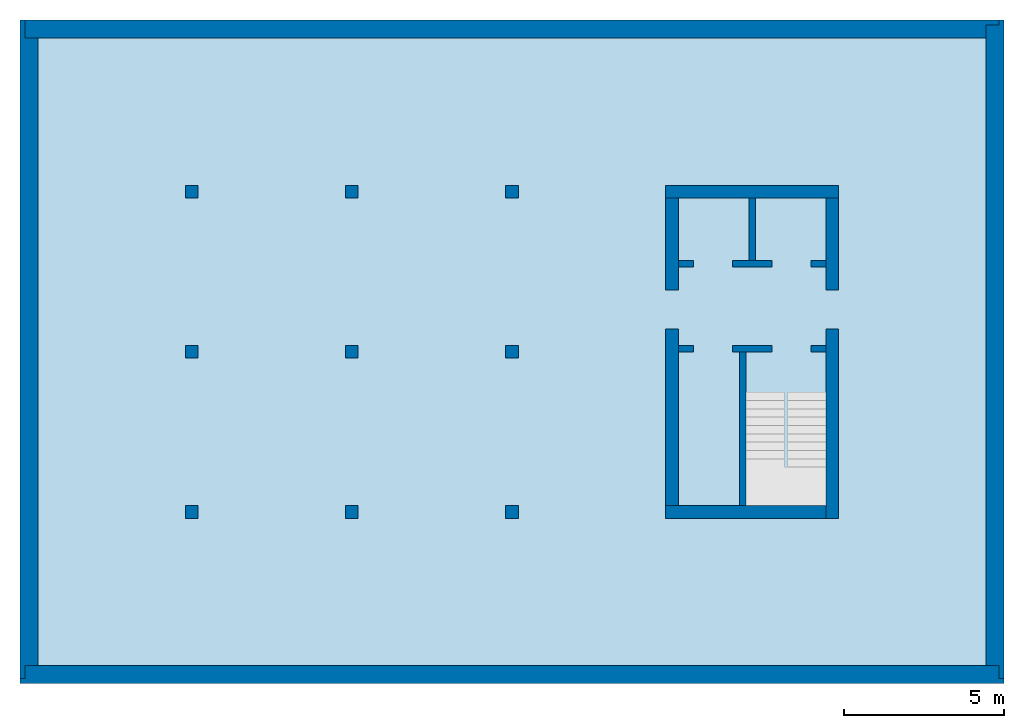
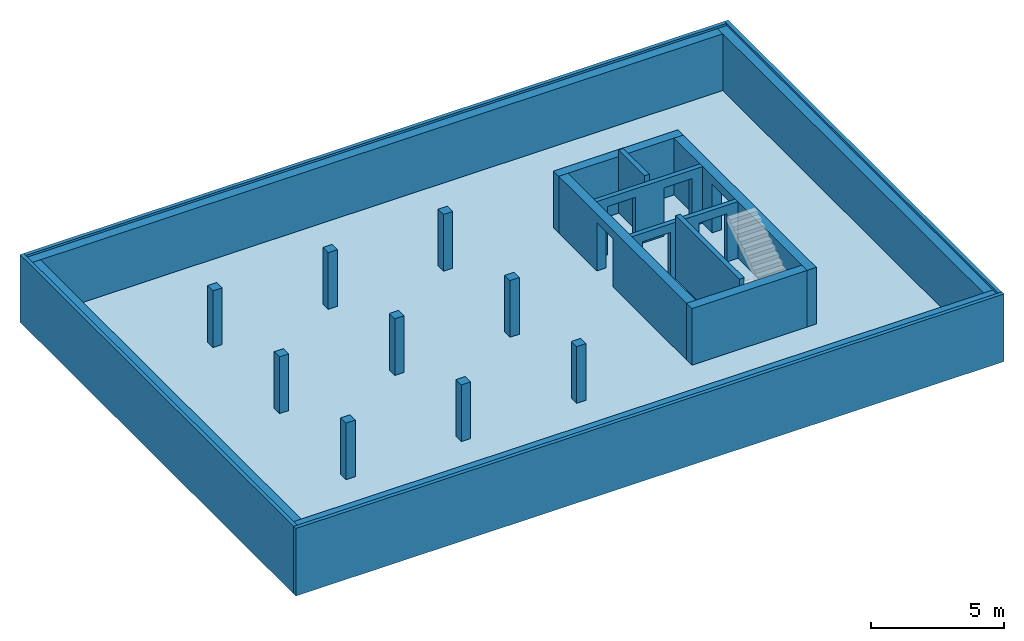
# One storey, part 1 of 2: 12 walls, 9 columns, 1 slab, 6 openings.
"""IFC2X3 building model written with IfcOpenShell, lengths in metres."""

from ifc_helpers import new_model, entity, si_unit, converted_unit, frame, frame_2d, origin, origin_with_axes, place, context, subcontext, project, spatial, polyline, rectangle, outline, extrude, clip, bounded_halfspace, material, layer, layer_set, layer_usage, element, save


model = new_model("IFC2X3")

# Units and contexts
model_context = context("Model", 3, precision=1e-05, world=origin())
body_context = subcontext(model_context, "Body", "Model", "MODEL_VIEW")
ifc_project = project(units=[si_unit("LENGTHUNIT", "METRE"), si_unit("AREAUNIT", "SQUARE_METRE"), si_unit("VOLUMEUNIT", "CUBIC_METRE"), si_unit("MASSUNIT", "GRAM", prefix="KILO"), converted_unit("PLANEANGLEUNIT", "DEGREE", entity("IfcPlaneAngleMeasure", 0.0174532925199433), si_unit("PLANEANGLEUNIT", "RADIAN"), dimensions=[0, 0, 0, 0, 0, 0, 0])], contexts=[model_context])

# Site, building, storey
site_placement = place(None, origin())
site = spatial("IfcSite", under=ifc_project, at=site_placement, CompositionType="ELEMENT")
building_placement = place(site_placement, origin())
building = spatial("IfcBuilding", under=site, at=building_placement, CompositionType="ELEMENT")
storey_placement = place(building_placement, frame((0.0, 0.0, -3.1)))
storey = spatial("IfcBuildingStorey", under=building, at=storey_placement, Name="Untergeschoss", CompositionType="ELEMENT", Elevation=-3.1)

# Columns
ifc_material_1 = material(Name="C30/37")
column_1_placement = place(storey_placement, frame((15.0, 15.0, 0.0)))
element("IfcColumn", 1, at=column_1_placement, inside=storey, material=ifc_material_1, Name="UG", context=body_context, shape_type="SweptSolid", body=[
    extrude(rectangle(XDim=0.4, YDim=0.4, at=frame_2d((0.2, 0.2), x_axis=(1.0, 0.0))), origin_with_axes(), (0.0, 0.0, 1.0), 2.6),
])
ifc_material_2 = material(Name="C30/37")
column_2_placement = place(storey_placement, frame((10.0, 15.0, 0.0)))
element("IfcColumn", 2, at=column_2_placement, inside=storey, material=ifc_material_2, Name="UG", context=body_context, shape_type="SweptSolid", body=[
    extrude(rectangle(XDim=0.4, YDim=0.4, at=frame_2d((0.2, 0.2), x_axis=(1.0, 0.0))), origin_with_axes(), (0.0, 0.0, 1.0), 2.6),
])
ifc_material_3 = material(Name="C30/37")
column_3_placement = place(storey_placement, frame((5.0, 15.0, 0.0)))
element("IfcColumn", 3, at=column_3_placement, inside=storey, material=ifc_material_3, Name="UG", context=body_context, shape_type="SweptSolid", body=[
    extrude(rectangle(XDim=0.4, YDim=0.4, at=frame_2d((0.2, 0.2), x_axis=(1.0, 0.0))), origin_with_axes(), (0.0, 0.0, 1.0), 2.6),
])
ifc_material_4 = material(Name="C30/37")
column_4_placement = place(storey_placement, frame((15.0, 10.0, 0.0)))
element("IfcColumn", 4, at=column_4_placement, inside=storey, material=ifc_material_4, Name="UG", context=body_context, shape_type="SweptSolid", body=[
    extrude(rectangle(XDim=0.4, YDim=0.4, at=frame_2d((0.2, 0.2), x_axis=(1.0, 0.0))), origin_with_axes(), (0.0, 0.0, 1.0), 2.6),
])
ifc_material_5 = material(Name="C30/37")
column_5_placement = place(storey_placement, frame((10.0, 10.0, 0.0)))
element("IfcColumn", 5, at=column_5_placement, inside=storey, material=ifc_material_5, Name="UG", context=body_context, shape_type="SweptSolid", body=[
    extrude(rectangle(XDim=0.4, YDim=0.4, at=frame_2d((0.2, 0.2), x_axis=(1.0, 0.0))), origin_with_axes(), (0.0, 0.0, 1.0), 2.6),
])
ifc_material_6 = material(Name="C30/37")
column_6_placement = place(storey_placement, frame((5.0, 10.0, 0.0)))
element("IfcColumn", 6, at=column_6_placement, inside=storey, material=ifc_material_6, Name="UG", context=body_context, shape_type="SweptSolid", body=[
    extrude(rectangle(XDim=0.4, YDim=0.4, at=frame_2d((0.2, 0.2), x_axis=(1.0, 0.0))), origin_with_axes(), (0.0, 0.0, 1.0), 2.6),
])
ifc_material_7 = material(Name="C30/37")
column_7_placement = place(storey_placement, frame((10.0, 5.0, 0.0)))
element("IfcColumn", 7, at=column_7_placement, inside=storey, material=ifc_material_7, Name="UG", context=body_context, shape_type="SweptSolid", body=[
    extrude(rectangle(XDim=0.4, YDim=0.4, at=frame_2d((0.2, 0.2), x_axis=(1.0, 0.0))), origin_with_axes(), (0.0, 0.0, 1.0), 2.6),
])
ifc_material_8 = material(Name="C30/37")
column_8_placement = place(storey_placement, frame((5.0, 5.0, 0.0)))
element("IfcColumn", 8, at=column_8_placement, inside=storey, material=ifc_material_8, Name="UG", context=body_context, shape_type="SweptSolid", body=[
    extrude(rectangle(XDim=0.4, YDim=0.4, at=frame_2d((0.2, 0.2), x_axis=(1.0, 0.0))), origin_with_axes(), (0.0, 0.0, 1.0), 2.6),
])
ifc_material_9 = material(Name="C30/37")
column_9_placement = place(storey_placement, frame((15.0, 5.0, 0.0)))
element("IfcColumn", 9, at=column_9_placement, inside=storey, material=ifc_material_9, Name="UG", context=body_context, shape_type="SweptSolid", body=[
    extrude(rectangle(XDim=0.4, YDim=0.4, at=frame_2d((0.2, 0.2), x_axis=(1.0, 0.0))), origin_with_axes(), (0.0, 0.0, 1.0), 2.6),
])

# Slab
ifc_material_10 = material(Name="C25/30")
slab_placement = place(storey_placement, frame((0.0, 0.0, -0.4)))
element("IfcSlab", 10, at=slab_placement, inside=storey, material=ifc_material_10, PredefinedType="BASESLAB", context=body_context, shape_type="SweptSolid", body=[
    extrude(rectangle(XDim=30.4, YDim=20.4, at=frame_2d((15.2, 10.2), x_axis=(1.0, 0.0))), origin_with_axes(), (0.0, 0.0, 1.0), 0.4),
])

# Walls
ifc_material_11 = material(Name="C30/37")
ifc_layer_1 = layer(ifc_material_11, 0.4)
ifc_material_12 = material()
ifc_layer_2 = layer(ifc_material_12, 0.160000000000004)
ifc_layer_set_1 = layer_set([ifc_layer_1, ifc_layer_2])
ifc_layer_usage_1 = layer_usage(ifc_layer_set_1, "AXIS2", "POSITIVE", 0.0)
wall_1_placement = place(storey_placement, frame((30.0, 20.4, -0.4), z_axis=(0.0, 0.0, 1.0), x_axis=(0.0, -1.0, 0.0)))
element("IfcWallStandardCase", 11, at=wall_1_placement, inside=storey, material=ifc_layer_usage_1, context=body_context, shape_type="Clipping", body=[
    clip(clip(extrude(outline(polyline([(-20.4, 0.0), (-0.4, 0.0), (-0.4, 0.4), (0.0, 0.4), (0.0, 0.56), (-20.56, 0.56), (-20.56, 0.4), (-20.4, 0.4), (-20.4, 0.0)])), frame((20.4, 0.0, 0.0), z_axis=(0.0, 0.0, 1.0), x_axis=(1.0, 0.0, 0.0)), (0.0, 0.0, 1.0), 3.1), bounded_halfspace(frame((10.0, 0.200000000000004, 0.4), z_axis=(0.0, 0.0, 1.0), x_axis=(0.0, -1.0, 0.0)), True, origin_with_axes(), polyline([(0.0, 0.400000000000004), (0.0, 3.63797880709171e-15), (20.0, 3.63797880709171e-15), (20.0, 0.400000000000004), (0.0, 0.400000000000004)]))), bounded_halfspace(frame((10.0, 0.200000000000004, 3.0), z_axis=(0.0, 0.0, -1.0), x_axis=(1.0, 0.0, 0.0)), True, origin_with_axes(), polyline([(0.0, 3.63797880709171e-15), (20.0, 3.63797880709171e-15), (20.0, 0.400000000000004), (0.0, 0.400000000000004), (0.0, 3.63797880709171e-15)]))),
])
ifc_material_13 = material(Name="C30/37")
ifc_layer_3 = layer(ifc_material_13, 0.4)
ifc_material_14 = material()
ifc_layer_4 = layer(ifc_material_14, 0.16)
ifc_layer_set_2 = layer_set([ifc_layer_3, ifc_layer_4])
ifc_layer_usage_2 = layer_usage(ifc_layer_set_2, "AXIS2", "POSITIVE", 0.0)
wall_2_placement = place(storey_placement, frame((0.4, 0.4, -0.4), z_axis=(0.0, 0.0, 1.0), x_axis=(0.0, 1.0, 0.0)))
element("IfcWallStandardCase", 12, at=wall_2_placement, inside=storey, material=ifc_layer_usage_2, context=body_context, shape_type="Clipping", body=[
    clip(clip(extrude(outline(polyline([(0.4, -0.56), (20.0, -0.56), (20.0, -0.16), (20.56, -0.16), (20.56, 0.0), (0.0, 0.0), (0.0, -0.16), (0.4, -0.16), (0.4, -0.56)])), frame((-0.4, 0.56, 0.0), z_axis=(0.0, 0.0, 1.0), x_axis=(1.0, 0.0, 0.0)), (0.0, 0.0, 1.0), 3.1), bounded_halfspace(frame((9.8, 0.2, 0.4), z_axis=(0.0, 0.0, 1.0), x_axis=(0.0, -1.0, 0.0)), True, origin_with_axes(), polyline([(-1.81898940354586e-15, 0.4), (-1.81898940354586e-15, 0.0), (19.6, 0.0), (19.6, 0.4), (-1.81898940354586e-15, 0.4)]))), bounded_halfspace(frame((9.8, 0.2, 3.0), z_axis=(0.0, 0.0, -1.0), x_axis=(1.0, 0.0, 0.0)), True, origin_with_axes(), polyline([(-1.81898940354586e-15, 0.0), (19.6, 0.0), (19.6, 0.4), (-1.81898940354586e-15, 0.4), (-1.81898940354586e-15, 0.0)]))),
])
ifc_material_15 = material(Name="C30/37")
ifc_layer_5 = layer(ifc_material_15, 0.4)
ifc_material_16 = material()
ifc_layer_6 = layer(ifc_material_16, 0.16)
ifc_layer_set_3 = layer_set([ifc_layer_5, ifc_layer_6])
ifc_layer_usage_3 = layer_usage(ifc_layer_set_3, "AXIS2", "POSITIVE", 0.0)
wall_3_placement = place(storey_placement, frame((30.4, 0.4, -0.4), z_axis=(0.0, 0.0, 1.0), x_axis=(-1.0, 0.0, 0.0)))
element("IfcWallStandardCase", 13, at=wall_3_placement, inside=storey, material=ifc_layer_usage_3, context=body_context, shape_type="Clipping", body=[
    clip(clip(extrude(outline(polyline([(-30.56, -0.56), (-0.16, -0.56), (-0.16, -0.16), (0.0, -0.16), (0.0, 0.0), (-30.72, 0.0), (-30.72, -0.16), (-30.56, -0.16), (-30.56, -0.56)])), frame((30.56, 0.56, 0.0), z_axis=(0.0, 0.0, 1.0), x_axis=(1.0, 0.0, 0.0)), (0.0, 0.0, 1.0), 3.1), bounded_halfspace(frame((15.2, 0.2, 0.4), z_axis=(0.0, 0.0, 1.0), x_axis=(0.0, -1.0, 0.0)), True, origin_with_axes(), polyline([(0.0, 0.4), (0.0, 0.0), (30.4, 0.0), (30.4, 0.4), (0.0, 0.4)]))), bounded_halfspace(frame((15.2, 0.2, 3.0), z_axis=(0.0, 0.0, -1.0), x_axis=(1.0, 0.0, 0.0)), True, origin_with_axes(), polyline([(0.0, 0.0), (30.4, 0.0), (30.4, 0.4), (0.0, 0.4), (0.0, 0.0)]))),
])
ifc_material_17 = material(Name="C30/37")
ifc_layer_7 = layer(ifc_material_17, 0.4)
ifc_material_18 = material()
ifc_layer_8 = layer(ifc_material_18, 0.16)
ifc_layer_set_4 = layer_set([ifc_layer_7, ifc_layer_8])
ifc_layer_usage_4 = layer_usage(ifc_layer_set_4, "AXIS2", "POSITIVE", 0.0)
wall_4_placement = place(storey_placement, frame((0.0, 20.0, -0.4)))
element("IfcWallStandardCase", 14, at=wall_4_placement, inside=storey, material=ifc_layer_usage_4, context=body_context, shape_type="Clipping", body=[
    clip(clip(extrude(outline(polyline([(0.0, 0.0), (30.0, 0.0), (30.0, 0.4), (30.4, 0.4), (30.4, 0.56), (0.0, 0.56), (0.0, 0.0)])), origin_with_axes(), (0.0, 0.0, 1.0), 3.1), bounded_halfspace(frame((15.0, 0.199999999999996, 0.4), z_axis=(0.0, 0.0, 1.0), x_axis=(0.0, -1.0, 0.0)), True, origin_with_axes(), polyline([(0.0, 0.399999999999996), (0.0, -3.63797880709171e-15), (30.0, -3.63797880709171e-15), (30.0, 0.399999999999996), (0.0, 0.399999999999996)]))), bounded_halfspace(frame((15.0, 0.199999999999996, 3.0), z_axis=(0.0, 0.0, -1.0), x_axis=(1.0, 0.0, 0.0)), True, origin_with_axes(), polyline([(0.0, -3.63797880709171e-15), (30.0, -3.63797880709171e-15), (30.0, 0.399999999999996), (0.0, 0.399999999999996), (0.0, -3.63797880709171e-15)]))),
])

# Wall, openings
ifc_material_19 = material(Name="C25/30")
ifc_layer_9 = layer(ifc_material_19, 0.2)
ifc_layer_set_5 = layer_set([ifc_layer_9])
ifc_layer_usage_5 = layer_usage(ifc_layer_set_5, "AXIS2", "POSITIVE", -0.2)
wall_5_placement = place(storey_placement, frame((25.0, 10.4, 0.0), z_axis=(0.0, 0.0, 1.0), x_axis=(-1.0, 0.0, 0.0)))
wall_5 = element("IfcWallStandardCase", 15, at=wall_5_placement, inside=storey, material=ifc_layer_usage_5, Name="IW Beton", context=body_context, shape_type="SweptSolid", body=[
    extrude(rectangle(XDim=4.6, YDim=0.2, at=frame_2d((2.3, 0.1), x_axis=(1.0, 0.0))), origin_with_axes(), (0.0, 0.0, 1.0), 2.6),
])
opening_1_placement = place(wall_5_placement, frame((4.13, 0.2, 0.0), z_axis=(0.0, -1.0, 0.0), x_axis=(0.0, 0.0, 1.0)))
element("IfcOpeningElement", 16, at=opening_1_placement, cuts=wall_5, ObjectType="Opening", context=body_context, shape_type="SweptSolid", body=[
    extrude(outline(polyline([(0.0, 1.21), (2.21, 1.21), (2.21, 0.0), (0.0, 0.0), (0.0, 1.21)])), origin_with_axes(), (0.0, 0.0, 1.0), 0.2),
])
opening_2_placement = place(wall_5_placement, frame((1.68, 0.2, 0.0), z_axis=(0.0, -1.0, 0.0), x_axis=(0.0, 0.0, 1.0)))
element("IfcOpeningElement", 17, at=opening_2_placement, cuts=wall_5, ObjectType="Opening", context=body_context, shape_type="SweptSolid", body=[
    extrude(outline(polyline([(0.0, 1.21), (2.21, 1.21), (2.21, 0.0), (0.0, 0.0), (0.0, 1.21)])), origin_with_axes(), (0.0, 0.0, 1.0), 0.2),
])

ifc_material_20 = material(Name="C25/30")
ifc_layer_10 = layer(ifc_material_20, 0.2)
ifc_layer_set_6 = layer_set([ifc_layer_10])
ifc_layer_usage_6 = layer_usage(ifc_layer_set_6, "AXIS2", "POSITIVE", 0.0)
wall_6_placement = place(storey_placement, frame((25.0, 13.05, 0.0), z_axis=(0.0, 0.0, 1.0), x_axis=(-1.0, 0.0, 0.0)))
wall_6 = element("IfcWallStandardCase", 18, at=wall_6_placement, inside=storey, material=ifc_layer_usage_6, Name="IW Beton", context=body_context, shape_type="SweptSolid", body=[
    extrude(rectangle(XDim=4.6, YDim=0.2, at=frame_2d((2.3, 0.1), x_axis=(1.0, 0.0))), origin_with_axes(), (0.0, 0.0, 1.0), 2.6),
])
opening_3_placement = place(wall_6_placement, frame((1.68, 0.2, 0.0), z_axis=(0.0, -1.0, 0.0), x_axis=(0.0, 0.0, 1.0)))
element("IfcOpeningElement", 19, at=opening_3_placement, cuts=wall_6, ObjectType="Opening", context=body_context, shape_type="SweptSolid", body=[
    extrude(outline(polyline([(0.0, 1.21), (2.21, 1.21), (2.21, 0.0), (0.0, 0.0), (0.0, 1.21)])), origin_with_axes(), (0.0, 0.0, 1.0), 0.2),
])
opening_4_placement = place(wall_6_placement, frame((4.13, 0.2, 0.0), z_axis=(0.0, -1.0, 0.0), x_axis=(0.0, 0.0, 1.0)))
element("IfcOpeningElement", 20, at=opening_4_placement, cuts=wall_6, ObjectType="Opening", context=body_context, shape_type="SweptSolid", body=[
    extrude(outline(polyline([(0.0, 1.21), (2.21, 1.21), (2.21, 0.0), (0.0, 0.0), (0.0, 1.21)])), origin_with_axes(), (0.0, 0.0, 1.0), 0.2),
])

# Walls
ifc_material_21 = material(Name="C25/30")
ifc_layer_11 = layer(ifc_material_21, 0.2)
ifc_layer_set_7 = layer_set([ifc_layer_11])
ifc_layer_usage_7 = layer_usage(ifc_layer_set_7, "AXIS2", "POSITIVE", -0.2)
wall_7_placement = place(storey_placement, frame((22.3, 10.2, 0.0), z_axis=(0.0, 0.0, 1.0), x_axis=(0.0, -1.0, 0.0)))
element("IfcWallStandardCase", 21, at=wall_7_placement, inside=storey, material=ifc_layer_usage_7, Name="IW Beton", context=body_context, shape_type="SweptSolid", body=[
    extrude(rectangle(XDim=4.8, YDim=0.2, at=frame_2d((2.4, 0.1), x_axis=(1.0, 0.0))), origin_with_axes(), (0.0, 0.0, 1.0), 2.9),
])
ifc_material_22 = material(Name="C25/30")
ifc_layer_12 = layer(ifc_material_22, 0.2)
ifc_layer_set_8 = layer_set([ifc_layer_12])
ifc_layer_usage_8 = layer_usage(ifc_layer_set_8, "AXIS2", "POSITIVE", -0.1)
wall_8_placement = place(storey_placement, frame((22.6, 15.0, 0.0), z_axis=(0.0, 0.0, 1.0), x_axis=(0.0, -1.0, 0.0)))
element("IfcWallStandardCase", 22, at=wall_8_placement, inside=storey, material=ifc_layer_usage_8, Name="IW Beton", context=body_context, shape_type="SweptSolid", body=[
    extrude(rectangle(XDim=1.95, YDim=0.2, at=frame_2d((0.975, 0.1), x_axis=(1.0, 0.0))), origin_with_axes(), (0.0, 0.0, 1.0), 2.9),
])

# Wall, opening
ifc_material_23 = material(Name="C25/30")
ifc_layer_13 = layer(ifc_material_23, 0.4)
ifc_layer_set_9 = layer_set([ifc_layer_13])
ifc_layer_usage_9 = layer_usage(ifc_layer_set_9, "AXIS2", "POSITIVE", -0.2)
wall_9_placement = place(storey_placement, frame((25.0, 15.0, 0.0), z_axis=(0.0, 0.0, 1.0), x_axis=(0.0, -1.0, 0.0)))
wall_9 = element("IfcWallStandardCase", 23, at=wall_9_placement, inside=storey, material=ifc_layer_usage_9, context=body_context, shape_type="SweptSolid", body=[
    extrude(rectangle(XDim=10.0, YDim=0.4, at=frame_2d((5.0, 0.2), x_axis=(1.0, 0.0))), origin_with_axes(), (0.0, 0.0, 1.0), 2.6),
])
opening_5_placement = place(wall_9_placement, frame((2.87, 0.0, 0.0), z_axis=(0.0, 1.0, 0.0), x_axis=(0.0, 0.0, 1.0)))
element("IfcOpeningElement", 24, at=opening_5_placement, cuts=wall_9, ObjectType="Opening", context=body_context, shape_type="SweptSolid", body=[
    extrude(outline(polyline([(0.0, 1.21), (2.21, 1.21), (2.21, 0.0), (0.0, 0.0), (0.0, 1.21)])), origin_with_axes(), (0.0, 0.0, 1.0), 0.4),
])

ifc_material_24 = material(Name="C25/30")
ifc_layer_14 = layer(ifc_material_24, 0.4)
ifc_layer_set_10 = layer_set([ifc_layer_14])
ifc_layer_usage_10 = layer_usage(ifc_layer_set_10, "AXIS2", "POSITIVE", -0.2)
wall_10_placement = place(storey_placement, frame((20.4, 5.4, 0.0), z_axis=(0.0, 0.0, 1.0), x_axis=(0.0, 1.0, 0.0)))
wall_10 = element("IfcWallStandardCase", 25, at=wall_10_placement, inside=storey, material=ifc_layer_usage_10, context=body_context, shape_type="SweptSolid", body=[
    extrude(rectangle(XDim=9.6, YDim=0.4, at=frame_2d((4.8, 0.2), x_axis=(1.0, 0.0))), origin_with_axes(), (0.0, 0.0, 1.0), 2.6),
])
opening_6_placement = place(wall_10_placement, frame((5.52, 0.0, 0.0), z_axis=(0.0, 1.0, 0.0), x_axis=(0.0, 0.0, 1.0)))
element("IfcOpeningElement", 26, at=opening_6_placement, cuts=wall_10, ObjectType="Opening", context=body_context, shape_type="SweptSolid", body=[
    extrude(outline(polyline([(0.0, 1.21), (2.21, 1.21), (2.21, 0.0), (0.0, 0.0), (0.0, 1.21)])), origin_with_axes(), (0.0, 0.0, 1.0), 0.4),
])

# Walls
ifc_material_25 = material(Name="C25/30")
ifc_layer_15 = layer(ifc_material_25, 0.4)
ifc_layer_set_11 = layer_set([ifc_layer_15])
ifc_layer_usage_11 = layer_usage(ifc_layer_set_11, "AXIS2", "POSITIVE", -0.2)
wall_11_placement = place(storey_placement, frame((20.0, 15.0, 0.0)))
element("IfcWallStandardCase", 27, at=wall_11_placement, inside=storey, material=ifc_layer_usage_11, context=body_context, shape_type="SweptSolid", body=[
    extrude(rectangle(XDim=5.4, YDim=0.4, at=frame_2d((2.7, 0.2), x_axis=(1.0, 0.0))), origin_with_axes(), (0.0, 0.0, 1.0), 2.6),
])
ifc_material_26 = material(Name="C25/30")
ifc_layer_16 = layer(ifc_material_26, 0.4)
ifc_layer_set_12 = layer_set([ifc_layer_16])
ifc_layer_usage_12 = layer_usage(ifc_layer_set_12, "AXIS2", "POSITIVE", -0.2)
wall_12_placement = place(storey_placement, frame((25.0, 5.4, 0.0), z_axis=(0.0, 0.0, 1.0), x_axis=(-1.0, 0.0, 0.0)))
element("IfcWallStandardCase", 28, at=wall_12_placement, inside=storey, material=ifc_layer_usage_12, context=body_context, shape_type="SweptSolid", body=[
    extrude(rectangle(XDim=5.0, YDim=0.4, at=frame_2d((2.5, 0.2), x_axis=(1.0, 0.0))), origin_with_axes(), (0.0, 0.0, 1.0), 2.6),
])

save(model, "model.ifc")
